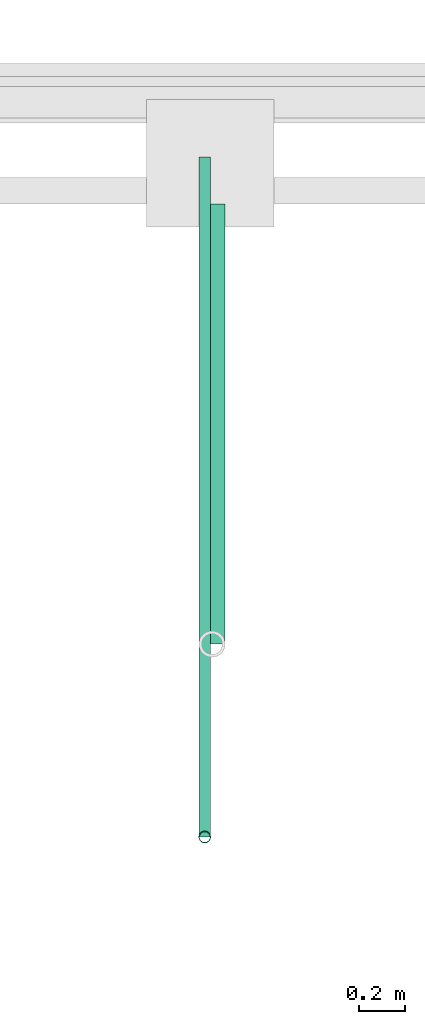
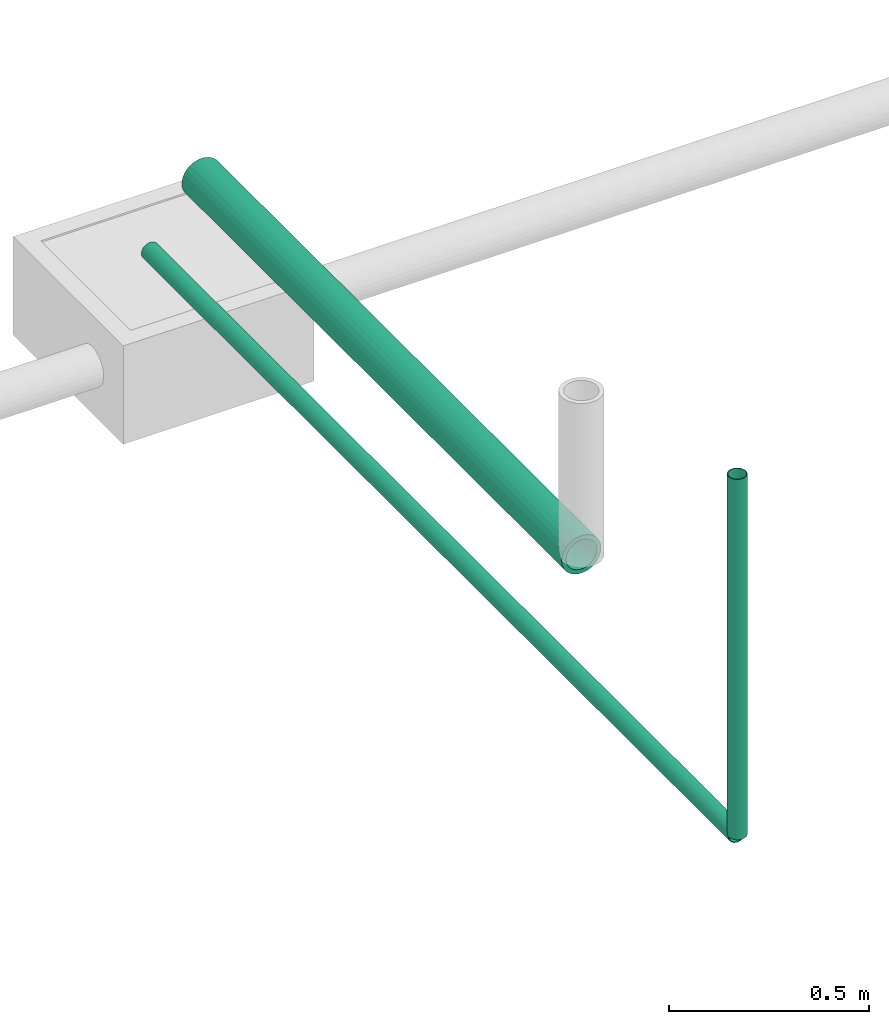
# One storey, part 7 of 15: 3 pipe segments.
"""IFC4X3_ADD2 building model written with IfcOpenShell, lengths in metres."""

from ifc_helpers import new_model, entity, si_unit, converted_unit, frame, origin_with_axes, origin_2d_with_axis, place, context, subcontext, project, spatial, hollow_circle, extrude, material, material_profile, profile_set, profile_usage, type_object, element, save


model = new_model("IFC4X3_ADD2")

# Units and contexts
model_context = context("Model", 3, precision=1e-05, world=origin_with_axes())
plan_context = context("Plan", 2, precision=1e-05, world=origin_2d_with_axis())
body_context = subcontext(model_context, "Body", "Model", "MODEL_VIEW")
ifc_project = project(units=[si_unit("VOLUMEUNIT", "CUBIC_METRE"), si_unit("LENGTHUNIT", "METRE"), converted_unit("PLANEANGLEUNIT", "degree", entity("IfcReal", 0.0174532925199433), si_unit("PLANEANGLEUNIT", "RADIAN"), dimensions=[0, 0, 0, 0, 0, 0, 0]), si_unit("AREAUNIT", "SQUARE_METRE")], contexts=[model_context, plan_context])

# Site, building, storey
site_placement = place(None, origin_with_axes())
site = spatial("IfcSite", under=ifc_project, at=site_placement)
building_placement = place(site_placement, origin_with_axes())
building = spatial("IfcBuilding", under=site, at=building_placement, Name="Building")
storey_placement = place(building_placement, origin_with_axes())
storey = spatial("IfcBuildingStorey", under=building, at=storey_placement, Name="Plumbing")

# Pipe segments
ifc_material_1 = material()
ifc_material_profile_1 = material_profile(ifc_material_1, hollow_circle(Radius=0.0571499988436699, WallThickness=0.012699999846518))
ifc_profile_set_1 = profile_set([ifc_material_profile_1])
ifc_profile_usage_1 = profile_usage(ifc_profile_set_1)
pipe_segment_type_1 = type_object("IfcPipeSegmentType", Name="4inch Tank", PredefinedType="FLEXIBLESEGMENT", material=ifc_profile_set_1)
pipe_segment_1_placement = place(storey_placement, frame((23.6584148406982, 24.895565032959, 0.387610822916031), z_axis=(8.74228049951849e-08, 0.999999999999995, 4.37113882867377e-08), x_axis=(-0.999999999999921, 8.74227907843236e-08, 3.89414367418763e-07)))
element("IfcPipeSegment", 1, at=pipe_segment_1_placement, inside=storey, type_object=pipe_segment_type_1, material=ifc_profile_usage_1, Name="PipeSegment", PredefinedType="FLEXIBLESEGMENT", context=body_context, shape_type="SweptSolid", body=[
    extrude(hollow_circle(Radius=0.0571499988436699, WallThickness=0.012699999846518), origin_with_axes(), (0.0, 0.0, 1.0), 1.89904022068139),
])
ifc_material_2 = material(Name="Wall")
ifc_material_profile_2 = material_profile(ifc_material_2, hollow_circle(Radius=0.0253999996930361, WallThickness=0.0020000000949949))
ifc_profile_set_2 = profile_set([ifc_material_profile_2])
ifc_profile_usage_2 = profile_usage(ifc_profile_set_2)
ifc_material_profile_3 = material_profile(ifc_material_2, hollow_circle(Radius=0.0253999996930361, WallThickness=0.0020000000949949))
ifc_profile_set_3 = profile_set([ifc_material_profile_3])
pipe_segment_type_2 = type_object("IfcPipeSegmentType", Name="2inch-bath outlet", PredefinedType="FLEXIBLESEGMENT", material=ifc_profile_set_3)
pipe_segment_2_placement = place(storey_placement, frame((23.6270809173584, 24.0626564025879, 0.0504299513995647), z_axis=(-8.74227481517655e-08, -1.19209317972489e-07, 0.999999999999989), x_axis=(-0.999999999999921, -3.89414367418763e-07, -8.7422797889751e-08)))
element("IfcPipeSegment", 2, at=pipe_segment_2_placement, inside=storey, type_object=pipe_segment_type_2, material=ifc_profile_usage_2, Name="PipeSegment", context=body_context, shape_type="SweptSolid", body=[
    extrude(hollow_circle(Radius=0.0253999996930361, WallThickness=0.0020000000949949), origin_with_axes(), (0.0, 0.0, 1.0), 1.09957002125543),
])
ifc_profile_usage_3 = profile_usage(ifc_profile_set_2)
pipe_segment_3_placement = place(storey_placement, frame((23.6270809173584, 24.0626564025879, 0.0504299513995647), z_axis=(-1.5099578831723e-07, 0.999999999999988, 4.37113882867374e-08), x_axis=(-0.999999999999913, -1.50995802528073e-07, 3.8941436741876e-07)))
element("IfcPipeSegment", 3, at=pipe_segment_3_placement, inside=storey, type_object=pipe_segment_type_2, material=ifc_profile_usage_3, Name="PipeSegment", context=body_context, shape_type="SweptSolid", body=[
    extrude(hollow_circle(Radius=0.0253999996930361, WallThickness=0.0020000000949949), origin_with_axes(), (0.0, 0.0, 1.0), 2.93512158793498),
])

save(model, "model.ifc")
